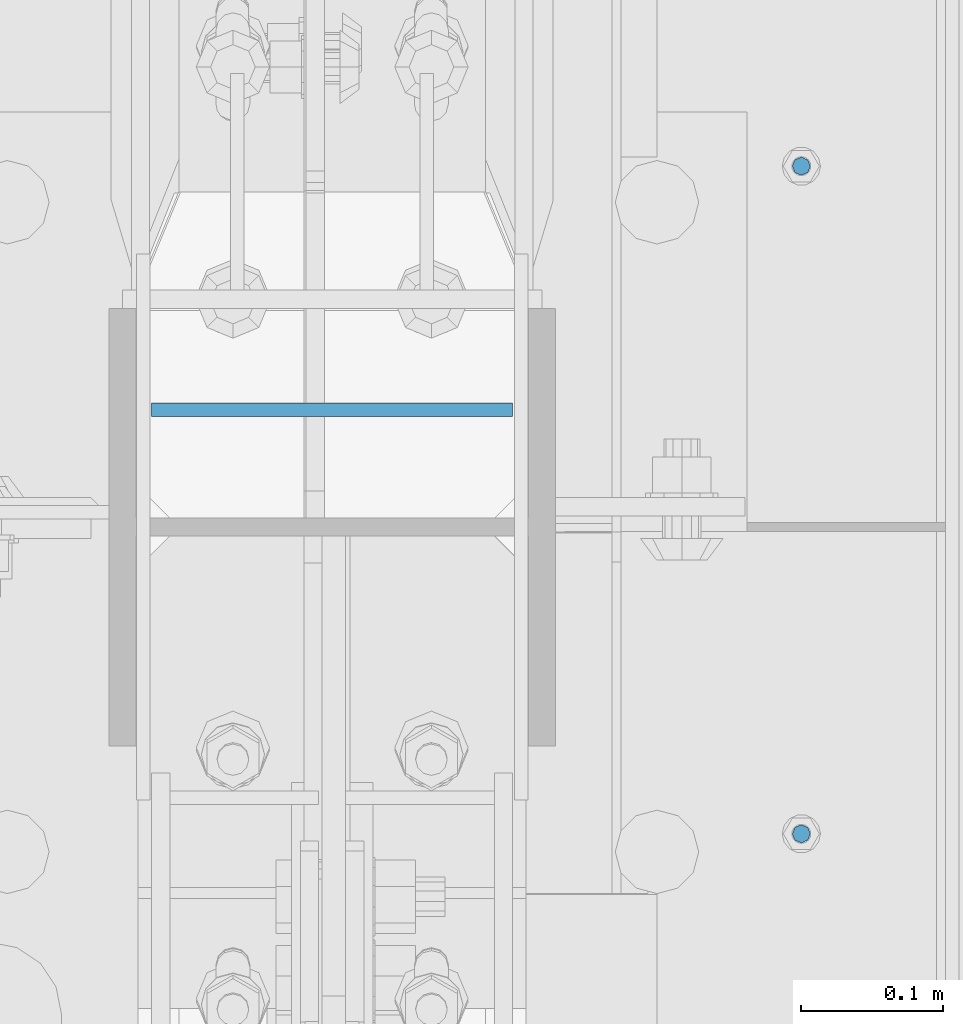
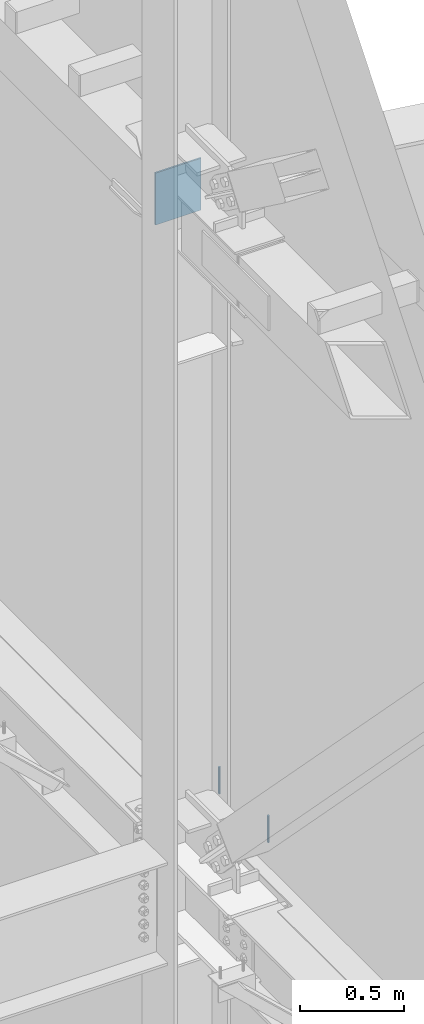
# One storey, part 443 of 1179: 3 columns, 3 elements without a shape of their own.
"""IFC2X3 building model written with IfcOpenShell, lengths in millimetres."""

from ifc_helpers import new_model, si_unit, frame, origin_with_axes, place, context, subcontext, project, spatial, faceted_brep, material, type_object, element, aggregate, save


model = new_model("IFC2X3")

# Units and contexts
model_context = context("Model", 3, precision=1e-05, world=origin_with_axes())
body_context = subcontext(model_context, "Body", "Model", "MODEL_VIEW")
ifc_project = project(units=[si_unit("LENGTHUNIT", "METRE", prefix="MILLI"), si_unit("AREAUNIT", "SQUARE_METRE"), si_unit("VOLUMEUNIT", "CUBIC_METRE"), si_unit("MASSUNIT", "GRAM", prefix="KILO"), si_unit("TIMEUNIT", "SECOND"), si_unit("PLANEANGLEUNIT", "RADIAN"), si_unit("SOLIDANGLEUNIT", "STERADIAN"), si_unit("THERMODYNAMICTEMPERATUREUNIT", "DEGREE_CELSIUS"), si_unit("LUMINOUSINTENSITYUNIT", "LUMEN")], contexts=[model_context])

# Site, building, storey
site_placement = place(None, origin_with_axes())
site = spatial("IfcSite", under=ifc_project, at=site_placement, CompositionType="ELEMENT")
building_placement = place(site_placement, origin_with_axes())
building = spatial("IfcBuilding", under=site, at=building_placement, Name="Undefined", CompositionType="ELEMENT")
storey_placement = place(building_placement, origin_with_axes())
storey = spatial("IfcBuildingStorey", under=building, at=storey_placement, Name="Undefined", CompositionType="ELEMENT", Elevation=0.0)

# Assembly, column
assembly_1_placement = place(storey_placement, origin_with_axes())
assembly_1 = element("IfcElementAssembly", 1, at=assembly_1_placement, inside=storey, Name="BEAM", AssemblyPlace="NOTDEFINED", PredefinedType="RIGID_FRAME")
ifc_material_1 = material(Name="STEEL/A307")
column_type_1 = type_object("IfcColumnType", PredefinedType="NOTDEFINED")
column_1_placement = place(assembly_1_placement, frame((24638.0, 19481.8, 4108.45), z_axis=(0.0, 1.0, 0.0), x_axis=(0.0, 0.0, 1.0)))
column_1 = element("IfcColumn", 2, at=column_1_placement, type_object=column_type_1, material=ifc_material_1, Name="THREADED ROD", context=body_context, shape_type="Brep", body=[
    faceted_brep([(0.0, -6.34999999999854, 0.0), (0.0, -4.49012806053361, -4.49012806053452), (157.162499999999, -4.49012806053361, -4.49012806053361), (157.162499999999, -6.34999999999854, 0.0), (0.0, 0.0, -6.34999999999991), (157.162499999999, 0.0, -6.34999999999854), (0.0, 4.49012806053361, -4.49012806053452), (157.162499999999, 4.49012806053361, -4.49012806053361), (0.0, 6.34999999999854, 0.0), (157.162499999999, 6.34999999999854, 0.0), (0.0, 4.49012806053361, 4.49012806053452), (157.162499999999, 4.49012806053361, 4.49012806053361), (0.0, 0.0, 6.34999999999991), (157.162499999999, 0.0, 6.34999999999854), (0.0, -4.49012806053361, 4.49012806053452), (157.162499999999, -4.49012806053361, 4.49012806053361)], [[[0, 1, 2, 3]], [[1, 4, 5, 2]], [[4, 6, 7, 5]], [[6, 8, 9, 7]], [[8, 10, 11, 9]], [[10, 12, 13, 11]], [[12, 14, 15, 13]], [[14, 0, 3, 15]], [[5, 7, 9, 11, 13, 15, 3, 2]], [[14, 12, 10, 8, 6, 4, 1, 0]]]),
])
aggregate(assembly_1, [column_1])

assembly_2_placement = place(storey_placement, origin_with_axes())
assembly_2 = element("IfcElementAssembly", 3, at=assembly_2_placement, inside=storey, Name="BEAM", AssemblyPlace="NOTDEFINED", PredefinedType="RIGID_FRAME")
column_2_placement = place(assembly_2_placement, frame((24638.0, 19011.9, 4108.45), z_axis=(0.0, 1.0, 0.0), x_axis=(0.0, 0.0, 1.0)))
column_2 = element("IfcColumn", 4, at=column_2_placement, type_object=column_type_1, material=ifc_material_1, Name="THREADED ROD", context=body_context, shape_type="Brep", body=[
    faceted_brep([(0.0, -6.34999999999854, 0.0), (0.0, -4.49012806053361, -4.49012806053452), (157.162499999999, -4.49012806053361, -4.49012806053361), (157.162499999999, -6.34999999999854, 0.0), (0.0, 0.0, -6.34999999999991), (157.162499999999, 0.0, -6.34999999999854), (0.0, 4.49012806053361, -4.49012806053452), (157.162499999999, 4.49012806053361, -4.49012806053361), (0.0, 6.34999999999854, 0.0), (157.162499999999, 6.34999999999854, 0.0), (0.0, 4.49012806053361, 4.49012806053452), (157.162499999999, 4.49012806053361, 4.49012806053361), (0.0, 0.0, 6.34999999999991), (157.162499999999, 0.0, 6.34999999999854), (0.0, -4.49012806053361, 4.49012806053452), (157.162499999999, -4.49012806053361, 4.49012806053361)], [[[0, 1, 2, 3]], [[1, 4, 5, 2]], [[4, 6, 7, 5]], [[6, 8, 9, 7]], [[8, 10, 11, 9]], [[10, 12, 13, 11]], [[12, 14, 15, 13]], [[14, 0, 3, 15]], [[5, 7, 9, 11, 13, 15, 3, 2]], [[14, 12, 10, 8, 6, 4, 1, 0]]]),
])
aggregate(assembly_2, [column_2])

assembly_3_placement = place(storey_placement, origin_with_axes())
assembly_3 = element("IfcElementAssembly", 5, at=assembly_3_placement, inside=storey, Name="BEAM", AssemblyPlace="NOTDEFINED", PredefinedType="RIGID_FRAME")
ifc_material_2 = material(Name="STEEL/A36")
column_type_2 = type_object("IfcColumnType", PredefinedType="NOTDEFINED")
column_3_placement = place(assembly_3_placement, frame((24307.8, 19310.35, 7708.90000000912), z_axis=(1.0, 0.0, 0.0), x_axis=(0.0, 0.0, 1.0)))
column_3 = element("IfcColumn", 6, at=column_3_placement, type_object=column_type_2, material=ifc_material_2, Name="PLATE", context=body_context, shape_type="Brep", body=[
    faceted_brep([(0.0, 4.76249999999982, -127.0), (0.0, 4.76249999999709, 127.0), (304.799999999999, 4.76249999999982, 127.0), (304.799999999999, 4.76249999999982, -127.0), (0.0, -4.76249999999709, 127.0), (304.799999999999, -4.76249999999982, 127.0), (0.0, -4.76249999999982, -127.0), (304.799999999999, -4.76249999999982, -127.0)], [[[0, 1, 2, 3]], [[1, 4, 5, 2]], [[4, 6, 7, 5]], [[6, 0, 3, 7]], [[5, 7, 3, 2]], [[6, 4, 1, 0]]]),
])
aggregate(assembly_3, [column_3])

save(model, "model.ifc")
